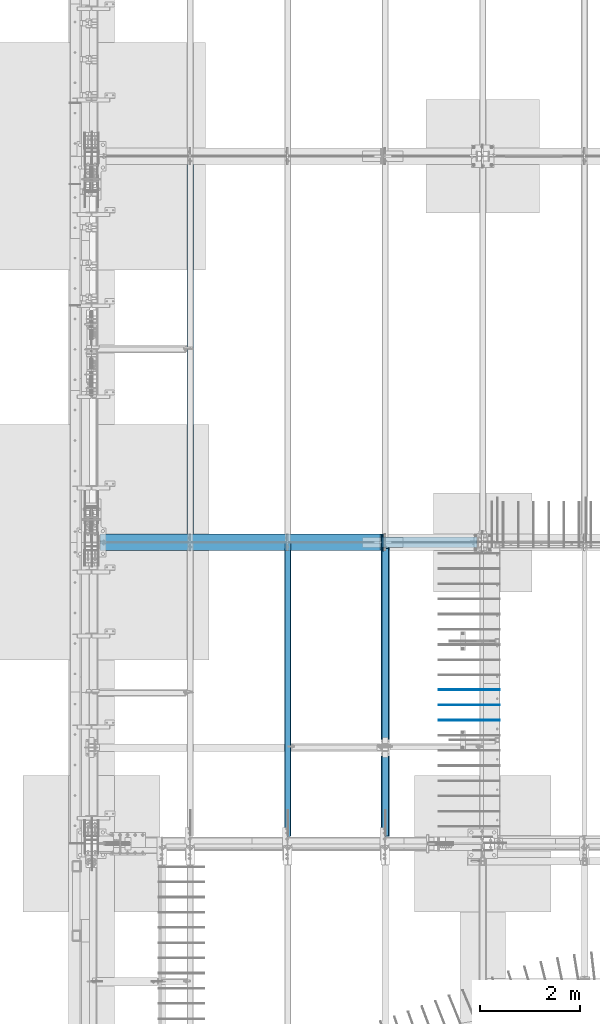
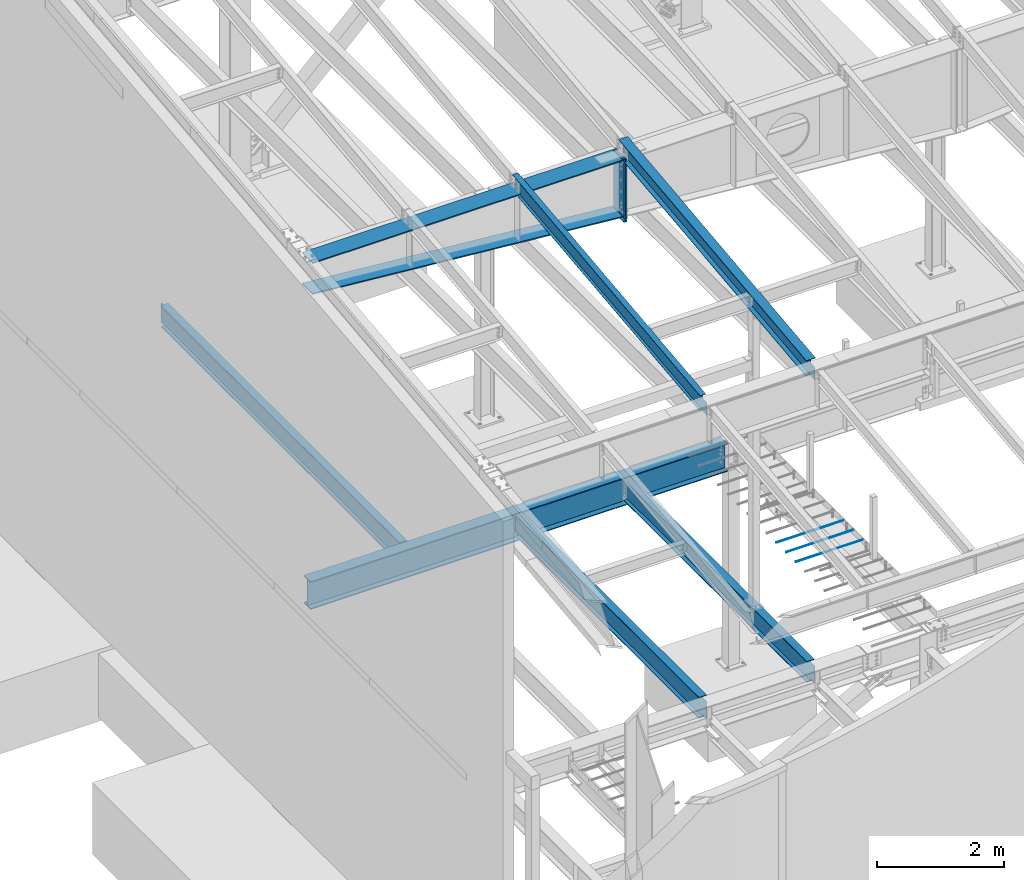
# One storey, part 709 of 1179: 13 beams, 11 elements without a shape of their own.
"""IFC2X3 building model written with IfcOpenShell, lengths in millimetres."""

from ifc_helpers import new_model, si_unit, frame, origin_with_axes, place, context, subcontext, project, spatial, faceted_brep, material, type_object, element, aggregate, save


model = new_model("IFC2X3")

# Units and contexts
model_context = context("Model", 3, precision=1e-05, world=origin_with_axes())
body_context = subcontext(model_context, "Body", "Model", "MODEL_VIEW")
ifc_project = project(units=[si_unit("LENGTHUNIT", "METRE", prefix="MILLI"), si_unit("AREAUNIT", "SQUARE_METRE"), si_unit("VOLUMEUNIT", "CUBIC_METRE"), si_unit("MASSUNIT", "GRAM", prefix="KILO"), si_unit("TIMEUNIT", "SECOND"), si_unit("PLANEANGLEUNIT", "RADIAN"), si_unit("SOLIDANGLEUNIT", "STERADIAN"), si_unit("THERMODYNAMICTEMPERATUREUNIT", "DEGREE_CELSIUS"), si_unit("LUMINOUSINTENSITYUNIT", "LUMEN")], contexts=[model_context])

# Site, building, storey
site_placement = place(None, origin_with_axes())
site = spatial("IfcSite", under=ifc_project, at=site_placement, CompositionType="ELEMENT")
building_placement = place(site_placement, origin_with_axes())
building = spatial("IfcBuilding", under=site, at=building_placement, Name="Undefined", CompositionType="ELEMENT")
storey_placement = place(building_placement, origin_with_axes())
storey = spatial("IfcBuildingStorey", under=building, at=storey_placement, Name="Undefined", CompositionType="ELEMENT", Elevation=0.0)

# Assembly, beam
assembly_1_placement = place(storey_placement, origin_with_axes())
assembly_1 = element("IfcElementAssembly", 1, at=assembly_1_placement, inside=storey, Name="BEAM", AssemblyPlace="NOTDEFINED", PredefinedType="RIGID_FRAME")
ifc_material_1 = material(Name="STEEL/A992")
beam_type_1 = type_object("IfcBeamType", Name="W12X14", PredefinedType="NOTDEFINED")
beam_1_placement = place(assembly_1_placement, frame((4368.8, 5452.5431792468, 9711.23798851528), z_axis=(0.0, -0.112284087038017, 0.993676146336441), x_axis=(0.0, 0.993676146336441, 0.112284087038017)))
beam_1 = element("IfcBeam", 2, at=beam_1_placement, type_object=beam_type_1, material=ifc_material_1, Name="BEAM", ObjectType="W12X14", context=body_context, shape_type="Brep", body=[
    faceted_brep([(-14.1944481268274, -2.38125000000036, -144.462499999927), (-14.9119897074661, -2.38115214811296, -150.812499999925), (137.488001223044, -2.38117577009325, -150.8125), (137.488001223013, -2.38125000000036, -144.462500000003), (137.48799371822, -50.7999999999993, -144.462500000005), (137.487993718216, -50.7999999999993, -150.812500000002), (5871.37503272929, 50.7999999999993, -144.462500002917), (5870.65749114864, 50.7999999999993, -150.812500002912), (137.488009517103, 50.7999999999993, -150.812500000002), (137.488009517107, 50.7999999999993, -144.462500000003), (137.488002012233, 2.3811758245356, -144.462500001737), (137.488002012265, 2.38132415558357, -150.812500000002), (-14.9119897074661, 2.38134777762207, -150.812499999925), (-14.1944481268274, 2.38125000000036, -144.462499999927), (5871.37503272928, 2.38124783346939, -144.462500002968), (6076.55490468175, 2.38124999999854, 144.462499996846), (6076.55490468175, 50.7999999999993, 144.462499996846), (6077.27244626239, 50.7999999999993, 150.812499996842), (6077.27244626239, -50.7999999999993, 150.812499996842), (6076.55490468175, -50.7999999999993, 144.462499996846), (6076.55490468175, -2.38124999999854, 144.462499996846), (6045.98095926941, -2.38124999999854, -126.106563095373), (6045.98095929506, 2.38124999999854, -126.10656309827), (5888.24414721426, -2.38124999999854, -108.282512497075), (5888.24414721426, 2.38122772319184, -108.282512497075), (5883.30625374162, -2.38124999999854, -108.697419370077), (5883.30625374162, 2.38122766974266, -108.697419370077), (5878.90301301472, -2.38124999999854, -110.970393360541), (5878.90301301472, 2.38122737693629, -110.970393360541), (5875.70477851863, -2.38124999999854, -114.755394783042), (5875.70477851863, 2.38122688934163, -114.755394783042), (5874.19845246322, -2.38124999999854, -119.476191482236), (5874.19845246322, 2.38122628119891, -119.476191482236), (5871.37503272929, -2.38124999999854, -144.462500002917), (5871.37503272929, -50.7999999999993, -144.462500002917), (5870.65749114864, -50.7999999999993, -150.812500002912), (-13.929041623056, -2.38125000000036, -142.113742318956), (12.2064158412222, -2.38125000000036, 89.176205714708), (12.2064158412222, 2.38125000000036, 89.176205714708), (-13.9290290466961, 2.38125000000036, -142.113631022425), (125.78359955719, -2.38125000000036, 76.342134544826), (125.78359955719, 2.38125000000036, 76.342134544826), (130.721493030343, -2.38125000000036, 76.7570414172296), (130.721493030343, 2.38125000000036, 76.7570414172296), (135.124733757862, -2.38125000000036, 79.0300154074976), (135.124733757862, 2.38125000000036, 79.0300154074976), (138.322968254461, -2.38125000000036, 82.8150168301745), (138.322968254461, 2.38125000000036, 82.8150168301745), (139.829294310099, -2.38125000000036, 87.5358135297793), (139.829294310099, 2.38125000000036, 87.5358135297793), (146.26193440305, 2.38125000000036, 144.46249999986), (146.26193440305, 50.7999999999993, 144.46249999986), (146.979475983694, 50.7999999999993, 150.812499999854), (146.979475983694, -50.7999999999993, 150.812499999854), (146.26193440305, -50.7999999999993, 144.46249999986), (146.26193440305, -2.38125000000036, 144.46249999986)], [[[0, 1, 2, 3]], [[4, 3, 2, 5]], [[6, 7, 8, 9]], [[10, 11, 12, 13]], [[9, 8, 11, 10]], [[14, 6, 9, 10]], [[15, 16, 17, 18, 19, 20, 21, 22]], [[21, 23, 24, 22]], [[25, 26, 24, 23]], [[27, 28, 26, 25]], [[29, 30, 28, 27]], [[31, 32, 30, 29]], [[33, 34, 35, 7, 6, 14, 32, 31]], [[35, 34, 4, 5]], [[1, 12, 11, 8, 7, 35, 5, 2]], [[36, 37, 38, 39, 13, 12, 1, 0]], [[40, 41, 38, 37]], [[42, 43, 41, 40]], [[44, 45, 43, 42]], [[46, 47, 45, 44]], [[48, 49, 47, 46]], [[15, 22, 24, 26, 28, 30, 32, 14, 10, 13, 39, 38, 41, 43, 45, 47, 49, 50]], [[16, 15, 50, 51]], [[17, 16, 51, 52]], [[18, 17, 52, 53]], [[19, 18, 53, 54]], [[20, 19, 54, 55]], [[53, 52, 51, 50, 49, 48, 55, 54]], [[46, 44, 42, 40, 37, 36, 0, 3, 33, 31, 29, 27, 25, 23, 21, 20, 55, 48]], [[34, 33, 3, 4]]]),
])
aggregate(assembly_1, [beam_1])

assembly_2_placement = place(storey_placement, origin_with_axes())
assembly_2 = element("IfcElementAssembly", 3, at=assembly_2_placement, inside=storey, Name="BEAM", AssemblyPlace="NOTDEFINED", PredefinedType="RIGID_FRAME")
beam_type_2 = type_object("IfcBeamType", Name="W16X31", PredefinedType="NOTDEFINED")
beam_2_placement = place(assembly_2_placement, frame((4368.80014508755, 5435.6, 3900.4875), z_axis=(0.0, 0.0, 1.0), x_axis=(0.0, 1.0, 0.0)))
beam_2 = element("IfcBeam", 4, at=beam_2_placement, type_object=beam_type_2, material=ifc_material_1, Name="BEAM", ObjectType="W16X31", context=body_context, shape_type="Brep", body=[
    faceted_brep([(19.0499999238054, -3.17500000000564, -147.6375), (19.0500000762049, 3.17499999999382, -147.6375), (141.287498514381, 3.17519843052196, -147.6375), (141.28749851438, -3.17500000003656, -147.6375), (146.147578032426, 3.17519914073091, -148.604229922588), (146.147578032425, -3.17500000003838, -148.604229922588), (150.26775450058, 3.175201160494, -151.357243823066), (150.267754500579, -3.17500000003838, -151.357243823066), (153.020768401058, 3.17520418232016, -155.47742029122), (153.020768401057, -3.1750000000402, -155.47742029122), (153.987498323645, -3.1750000000402, -160.337499809265), (153.987498323647, 3.17520774616514, -160.337499809265), (153.988000076218, 3.17556876199342, -190.5), (153.988000076218, 3.17556876199342, -201.6125), (153.987498323628, -69.8500000000395, -201.6125), (153.987498323628, -69.8500000000395, -190.5), (153.987498323645, -3.1750000000402, -190.5), (5900.73750167641, 69.8499999985015, -190.5), (5900.73750167641, 69.8499999985015, -201.6125), (153.988001676405, 69.8499999999603, -201.6125), (153.988001676405, 69.8499999999603, -190.5), (5900.73750007622, 3.17499999850133, -190.5), (5900.73750007622, 3.17542779204359, -201.6125), (6027.73750007621, 3.17499999846859, -190.5), (6027.73750007622, 3.17542474404308, -201.6125), (5927.72500167648, 69.8499999984942, 190.5), (5927.72500167647, 3.17499999849406, 190.5), (153.987498323646, 3.17499999996016, 190.5), (153.987498323663, 69.8499999999603, 190.5), (141.28749851438, -3.17500000003656, 169.8625), (141.287498514381, 3.17496707379814, 169.8625), (19.0500000762049, 3.17499999999382, 169.8625), (19.0499999238054, -3.17500000000564, 169.8625), (146.147578032425, -3.17500000003838, 170.829229922588), (146.147578032426, 3.17496636684882, 170.829229922588), (150.267754500579, -3.17500000003838, 173.582243823066), (150.26775450058, 3.17496435362955, 173.582243823066), (153.020768401057, -3.1750000000402, 177.702420291219), (153.020768401058, 3.17496134063458, 177.702420291219), (153.987498323645, -3.1750000000402, 182.562499809265), (153.987498323646, 3.17495778656485, 182.562499809265), (5927.72500167645, -69.8500000015056, 201.6125), (5927.72500167648, 69.8499999984942, 201.6125), (153.987498323663, 69.8499999999603, 201.6125), (153.987498323628, -69.8500000000395, 201.6125), (5927.72500167645, -69.8500000015056, 190.5), (153.987498323628, -69.8500000000395, 190.5), (5927.72500167647, -3.1750000015054, 190.5), (153.987498323645, -3.1750000000402, 190.5), (5927.72500167647, -3.1750000015054, 182.562499809265), (5927.72500167647, 3.17499999849406, 182.562499809265), (5928.69173159905, -3.1750000015054, 177.702420291219), (5928.69173159905, 3.17499999849406, 177.702420291219), (5931.44474549953, -3.17500000150721, 173.582243823066), (5931.44474549953, 3.17499999849315, 173.582243823066), (5935.56492196769, -3.17500000150812, 170.829229922588), (5935.56492196769, 3.17499999849224, 170.829229922588), (5940.42500148573, -3.17500000150903, 169.8625), (5940.42500148573, 3.17499999849133, 169.8625), (6027.73749992381, -3.17500000153177, 169.8625), (6027.73750007621, 3.17499999846859, 169.8625), (6027.73749992381, -3.17500000153177, -190.5), (6027.73749832361, -69.850000001531, -190.5), (6027.73749832361, -69.850000001531, -201.6125)], [[[0, 1, 2, 3]], [[3, 2, 4, 5]], [[5, 4, 6, 7]], [[7, 6, 8, 9]], [[10, 11, 12, 13, 14, 15, 16]], [[9, 8, 11, 10]], [[17, 18, 19, 20]], [[21, 22, 18, 17]], [[23, 24, 22, 21]], [[25, 26, 27, 28]], [[29, 30, 31, 32]], [[33, 34, 30, 29]], [[35, 36, 34, 33]], [[37, 38, 36, 35]], [[39, 40, 38, 37]], [[41, 42, 43, 44]], [[45, 41, 44, 46]], [[47, 45, 46, 48]], [[44, 43, 28, 27, 40, 39, 48, 46]], [[42, 25, 28, 43]], [[41, 45, 47, 49, 50, 26, 25, 42]], [[51, 52, 50, 49]], [[53, 54, 52, 51]], [[55, 56, 54, 53]], [[57, 58, 56, 55]], [[59, 60, 58, 57]], [[61, 62, 63, 24, 23, 60, 59]], [[62, 61, 16, 15]], [[63, 62, 15, 14]], [[19, 18, 22, 24, 63, 14, 13]], [[20, 19, 13, 12]], [[21, 17, 20, 12]], [[6, 4, 2, 1, 31, 30, 34, 36, 38, 40, 27, 26, 50, 52, 54, 56, 58, 60, 23, 21, 12, 11, 8]], [[32, 31, 1, 0]], [[61, 59, 57, 55, 53, 51, 49, 47, 48, 39, 37, 35, 33, 29, 32, 0, 3, 5, 7, 9, 10, 16]]]),
])
aggregate(assembly_2, [beam_2])

assembly_3_placement = place(storey_placement, origin_with_axes())
assembly_3 = element("IfcElementAssembly", 5, at=assembly_3_placement, inside=storey, Name="BEAM", AssemblyPlace="NOTDEFINED", PredefinedType="RIGID_FRAME")
beam_3_placement = place(assembly_3_placement, frame((2412.99985351563, 11480.8, 3900.4875), z_axis=(0.0, 0.0, 1.0), x_axis=(0.0, 1.0, 0.0)))
beam_3 = element("IfcBeam", 6, at=beam_3_placement, type_object=beam_type_2, material=ifc_material_1, Name="BEAM", ObjectType="W16X31", context=body_context, shape_type="Brep", body=[
    faceted_brep([(104.775000190735, -3.17499999999927, 169.8625), (104.775000190735, 3.17497090526012, 169.8625), (17.4625000000015, 3.17499999999927, 169.8625), (17.4625000000015, -3.17499999999927, 169.8625), (109.635079708782, -3.17499999999927, 170.829229922588), (109.635079708782, 3.17497028100843, 170.829229922588), (113.755256176935, -3.17499999999927, 173.582243823066), (113.755256176935, 3.17496850329189, 173.582243823066), (116.508270077413, -3.17499999999927, 177.702420291219), (116.508270077413, 3.17496584275432, 177.702420291219), (117.475, -3.17499999999927, 182.562499809265), (117.475, 3.17496270443371, 182.562499809265), (117.474999999999, -69.8499999999985, 201.6125), (117.474999999999, 69.8499999999985, 201.6125), (117.474999999999, 69.8499999999985, 190.5), (117.474999999999, 3.17499999999927, 190.5), (117.474999999999, -3.17499999999927, 190.5), (117.474999999999, -69.8499999999985, 190.5), (7601.74375, 3.17499999999927, -190.5), (7601.74375, 69.8499999999985, -190.5), (144.462499999994, 69.8499999999985, -190.5), (144.462499999994, 3.17549991607666, -190.5), (17.4624999999942, -3.17499999999927, -190.5), (17.4624999999942, -69.8499999999985, -190.5), (7728.74375, -69.8499999999985, -190.5), (7728.74375, -3.17499999999927, -190.5), (17.4624999999942, -69.8499999999985, -201.6125), (7728.74375, -69.8499999999985, -201.6125), (7601.74375, 69.8499999999985, -201.6125), (7601.74375, 3.17561705897606, -201.6125), (7728.74375, 3.17561705897606, -201.6125), (17.4624999999942, 3.17549991607666, -201.6125), (144.462499999994, 3.17549991607666, -201.6125), (144.462499999994, 69.8499999999985, -201.6125), (17.4624999999942, 3.17499999999927, -190.5), (7728.74375, 3.17499999999927, -190.5), (7728.74375, 3.17499999999927, 169.8625), (7728.74375, -3.17499999999927, 169.8625), (7633.49374980927, 3.17499999999927, 169.8625), (7633.49374980927, -3.17499999999927, 169.8625), (7628.63367029122, 3.17499999999927, 170.829229922588), (7628.63367029122, -3.17499999999927, 170.829229922588), (7624.51349382307, 3.17499999999927, 173.582243823066), (7624.51349382307, -3.17499999999927, 173.582243823066), (7621.76047992259, 3.17499999999927, 177.70242029122), (7621.76047992259, -3.17499999999927, 177.70242029122), (7620.79375, 3.17499999999927, 182.562499809265), (7620.79375, -3.17499999999927, 182.562499809265), (7620.79375, -69.8499999999985, 201.6125), (7620.79375, -69.8499999999985, 190.5), (7620.79375, -3.17499999999927, 190.5), (7620.79375, 3.17499999999927, 190.5), (7620.79375, 69.8499999999985, 190.5), (7620.79375, 69.8499999999985, 201.6125)], [[[0, 1, 2, 3]], [[4, 5, 1, 0]], [[6, 7, 5, 4]], [[8, 9, 7, 6]], [[10, 11, 9, 8]], [[12, 13, 14, 15, 11, 10, 16, 17]], [[18, 19, 20, 21]], [[22, 23, 24, 25]], [[23, 26, 27, 24]], [[28, 29, 30, 27, 26, 31, 32, 33]], [[21, 32, 31, 34]], [[20, 33, 32, 21]], [[19, 28, 33, 20]], [[18, 29, 28, 19]], [[35, 30, 29, 18]], [[25, 24, 27, 30, 35, 36, 37]], [[37, 36, 38, 39]], [[39, 38, 40, 41]], [[41, 40, 42, 43]], [[43, 42, 44, 45]], [[45, 44, 46, 47]], [[48, 49, 50, 47, 46, 51, 52, 53]], [[49, 48, 12, 17]], [[50, 49, 17, 16]], [[8, 6, 4, 0, 3, 22, 25, 37, 39, 41, 43, 45, 47, 50, 16, 10]], [[34, 31, 26, 23, 22, 3, 2]], [[51, 46, 44, 42, 40, 38, 36, 35, 18, 21, 34, 2, 1, 5, 7, 9, 11, 15]], [[52, 51, 15, 14]], [[53, 52, 14, 13]], [[48, 53, 13, 12]]]),
])
aggregate(assembly_3, [beam_3])

assembly_4_placement = place(storey_placement, origin_with_axes())
assembly_4 = element("IfcElementAssembly", 7, at=assembly_4_placement, inside=storey, Name="BEAM", AssemblyPlace="NOTDEFINED", PredefinedType="RIGID_FRAME")
beam_4_placement = place(assembly_4_placement, frame((6324.59996446262, 5435.6, 3900.4875), z_axis=(0.0, 0.0, 1.0), x_axis=(0.0, 1.0, 0.0)))
beam_4 = element("IfcBeam", 8, at=beam_4_placement, type_object=beam_type_2, material=ifc_material_1, Name="BEAM", ObjectType="W16X31", context=body_context, shape_type="Brep", body=[
    faceted_brep([(19.0499999238054, -3.17500000000564, -147.6375), (19.0500000762049, 3.17499999999382, -147.6375), (141.287498514381, 3.17519843052196, -147.6375), (141.28749851438, -3.17500000003656, -147.6375), (146.147578032426, 3.17519914073091, -148.604229922588), (146.147578032425, -3.17500000003838, -148.604229922588), (150.26775450058, 3.175201160494, -151.357243823066), (150.267754500579, -3.17500000003838, -151.357243823066), (153.020768401058, 3.17520418232016, -155.47742029122), (153.020768401057, -3.1750000000402, -155.47742029122), (153.987498323645, -3.1750000000402, -160.337499809265), (153.987498323647, 3.17520774616514, -160.337499809265), (153.987000000001, 3.17549991607757, -190.5), (153.987000000001, 3.17549991607757, -201.6125), (153.987498323628, -69.8500000000395, -201.6125), (153.987498323628, -69.8500000000395, -190.5), (153.987498323645, -3.1750000000402, -190.5), (5900.73750167641, 69.8499999985015, -190.5), (5900.73750167641, 69.8499999985015, -201.6125), (153.987000000001, 69.8500000000004, -201.6125), (153.987000000001, 69.8500000000004, -190.5), (5900.73750007622, 3.17499999850133, -190.5), (5900.73749999986, 3.17549991607666, -201.6125), (6027.73750007621, 3.17499999846859, -190.5), (6027.7375, 3.17549991607666, -201.6125), (5927.72500167648, 69.8499999984942, 190.5), (5927.72500167647, 3.17499999849406, 190.5), (153.987498323646, 3.17499999996016, 190.5), (153.987498323663, 69.8499999999603, 190.5), (141.28749851438, -3.17500000003656, 169.8625), (141.287498514381, 3.17496707379814, 169.8625), (19.0500000762049, 3.17499999999382, 169.8625), (19.0499999238054, -3.17500000000564, 169.8625), (146.147578032425, -3.17500000003838, 170.829229922588), (146.147578032426, 3.17496636684882, 170.829229922588), (150.267754500579, -3.17500000003838, 173.582243823066), (150.26775450058, 3.17496435362955, 173.582243823066), (153.020768401057, -3.1750000000402, 177.702420291219), (153.020768401058, 3.17496134063458, 177.702420291219), (153.987498323645, -3.1750000000402, 182.562499809265), (153.987498323646, 3.17495778656485, 182.562499809265), (5927.72500167645, -69.8500000015056, 201.6125), (5927.72500167648, 69.8499999984942, 201.6125), (153.987498323663, 69.8499999999603, 201.6125), (153.987498323628, -69.8500000000395, 201.6125), (5927.72500167645, -69.8500000015056, 190.5), (153.987498323628, -69.8500000000395, 190.5), (5927.72500167647, -3.1750000015054, 190.5), (153.987498323645, -3.1750000000402, 190.5), (5927.72500167647, -3.1750000015054, 182.562499809265), (5927.72500167647, 3.17499999849406, 182.562499809265), (5928.69173159905, -3.1750000015054, 177.702420291219), (5928.69173159905, 3.17499999849406, 177.702420291219), (5931.44474549953, -3.17500000150721, 173.582243823066), (5931.44474549953, 3.17499999849315, 173.582243823066), (5935.56492196769, -3.17500000150812, 170.829229922588), (5935.56492196769, 3.17499999849224, 170.829229922588), (5940.42500148573, -3.17500000150903, 169.8625), (5940.42500148573, 3.17499999849133, 169.8625), (6027.73749992381, -3.17500000153177, 169.8625), (6027.73750007621, 3.17499999846859, 169.8625), (6027.73749992381, -3.17500000153177, -190.5), (6027.73749832361, -69.850000001531, -190.5), (6027.73749832361, -69.850000001531, -201.6125)], [[[0, 1, 2, 3]], [[3, 2, 4, 5]], [[5, 4, 6, 7]], [[7, 6, 8, 9]], [[10, 11, 12, 13, 14, 15, 16]], [[9, 8, 11, 10]], [[17, 18, 19, 20]], [[21, 22, 18, 17]], [[23, 24, 22, 21]], [[25, 26, 27, 28]], [[29, 30, 31, 32]], [[33, 34, 30, 29]], [[35, 36, 34, 33]], [[37, 38, 36, 35]], [[39, 40, 38, 37]], [[41, 42, 43, 44]], [[45, 41, 44, 46]], [[47, 45, 46, 48]], [[44, 43, 28, 27, 40, 39, 48, 46]], [[42, 25, 28, 43]], [[41, 45, 47, 49, 50, 26, 25, 42]], [[51, 52, 50, 49]], [[53, 54, 52, 51]], [[55, 56, 54, 53]], [[57, 58, 56, 55]], [[59, 60, 58, 57]], [[61, 62, 63, 24, 23, 60, 59]], [[62, 61, 16, 15]], [[63, 62, 15, 14]], [[19, 18, 22, 24, 63, 14, 13]], [[20, 19, 13, 12]], [[21, 17, 20, 12]], [[6, 4, 2, 1, 31, 30, 34, 36, 38, 40, 27, 26, 50, 52, 54, 56, 58, 60, 23, 21, 12, 11, 8]], [[32, 31, 1, 0]], [[61, 59, 57, 55, 53, 51, 49, 47, 48, 39, 37, 35, 33, 29, 32, 0, 3, 5, 7, 9, 10, 16]]]),
])
aggregate(assembly_4, [beam_4])

assembly_5_placement = place(storey_placement, origin_with_axes())
assembly_5 = element("IfcElementAssembly", 9, at=assembly_5_placement, inside=storey, Name="RAFTER BEAM", AssemblyPlace="NOTDEFINED", PredefinedType="RIGID_FRAME")
ifc_material_2 = material(Name="STEEL/A36")
beam_type_3 = type_object("IfcBeamType", PredefinedType="NOTDEFINED")
beam_5_placement = place(assembly_5_placement, frame((6261.1, 11645.9093353614, 9647.25885710149), z_axis=(0.0, 0.0, 1.0), x_axis=(0.0, -1.0, 0.0)))
beam_5 = element("IfcBeam", 10, at=beam_5_placement, type_object=beam_type_3, material=ifc_material_2, Name="PLATE", context=body_context, shape_type="Brep", body=[
    faceted_brep([(0.0, 12.7000000000007, -604.8375), (0.0, 12.7000000000007, 604.8375), (330.199999998662, 12.7000000000007, 604.8375), (330.199999998662, 12.7000000000007, -604.8375), (0.0, -12.7000000000007, 604.8375), (330.199999998662, -12.7000000000007, 604.8375), (0.0, -12.7000000000007, -604.8375), (330.199999998662, -12.7000000000007, -604.8375)], [[[0, 1, 2, 3]], [[1, 4, 5, 2]], [[4, 6, 7, 5]], [[6, 0, 3, 7]], [[5, 7, 3, 2]], [[6, 4, 1, 0]]]),
])

assembly_6_placement = place(storey_placement, origin_with_axes())
assembly_6 = element("IfcElementAssembly", 11, at=assembly_6_placement, inside=storey, Name="RAFTER BEAM", AssemblyPlace="NOTDEFINED", PredefinedType="RIGID_FRAME")
beam_6_placement = place(assembly_6_placement, frame((6286.5, 11645.9093353614, 9647.25885710149), z_axis=(0.0, 0.0, 1.0), x_axis=(0.0, -1.0, 0.0)))
beam_6 = element("IfcBeam", 12, at=beam_6_placement, type_object=beam_type_3, material=ifc_material_2, Name="PLATE", context=body_context, shape_type="Brep", body=[
    faceted_brep([(0.0, 12.7000000000007, -604.8375), (0.0, 12.7000000000007, 604.8375), (330.199999998662, 12.7000000000007, 604.8375), (330.199999998662, 12.7000000000007, -604.8375), (0.0, -12.7000000000007, 604.8375), (330.199999998662, -12.7000000000007, 604.8375), (0.0, -12.7000000000007, -604.8375), (330.199999998662, -12.7000000000007, -604.8375)], [[[0, 1, 2, 3]], [[1, 4, 5, 2]], [[4, 6, 7, 5]], [[6, 0, 3, 7]], [[5, 7, 3, 2]], [[6, 4, 1, 0]]]),
])
aggregate(assembly_6, [beam_6])

# Beam
beam_type_4 = type_object("IfcBeamType", PredefinedType="NOTDEFINED")
beam_7_placement = place(assembly_5_placement, frame((600.692587263406, 11480.8093353628, 9653.73151088012), z_axis=(0.0, 1.0, 0.0), x_axis=(0.996183710890709, 0.0, -0.0872812359904244)))
beam_7 = element("IfcBeam", 13, at=beam_7_placement, type_object=beam_type_4, material=ifc_material_2, Name="PLATE", context=body_context, shape_type="Brep", body=[
    faceted_brep([(5670.3221448979, 11.172430163635, 165.1), (5643.908580592, -11.1125000006832, 165.1), (5643.908580592, -11.1125000006832, -165.1), (5670.31689408045, 11.1124999993244, -165.1), (1.66062363859965e-09, -11.1125000000084, -165.1), (1.66062363859965e-09, -11.1125000000084, 165.1), (1.94725676632936, 11.1125000000065, 165.1), (1.94725676632936, 11.1125000000065, -165.1)], [[[0, 1, 2, 3]], [[4, 5, 6, 7]], [[7, 6, 0, 3]], [[4, 7, 3, 2]], [[5, 4, 2, 1]], [[6, 5, 1, 0]]]),
])

beam_8_placement = place(assembly_5_placement, frame((601.662500000002, 11480.8093353614, 10240.98385672), z_axis=(0.0, -1.0, 0.0), x_axis=(1.0, 0.0, 0.0)))
beam_8 = element("IfcBeam", 14, at=beam_8_placement, type_object=beam_type_4, material=ifc_material_2, Name="PLATE", context=body_context, shape_type="Brep", body=[
    faceted_brep([(5646.7375, -11.1124999999993, 165.1), (5646.7375, -11.1124999999993, -165.1), (5624.51249961853, 11.1124999999993, -165.1), (5624.51249961853, 11.1124999999993, 165.1), (1.66062363859965e-09, -11.1125000000084, -165.1), (1.66062363859965e-09, -11.1125000000084, 165.1), (0.0, 11.1124999999993, 165.1), (0.0, 11.1124999999993, -165.1)], [[[0, 1, 2, 3]], [[4, 5, 6, 7]], [[6, 5, 0, 3]], [[7, 6, 3, 2]], [[4, 7, 2, 1]], [[5, 4, 1, 0]]]),
])

aggregate(assembly_5, [beam_5, beam_7, beam_8])

# Assembly, beam
assembly_7_placement = place(storey_placement, origin_with_axes())
assembly_7 = element("IfcElementAssembly", 15, at=assembly_7_placement, inside=storey, Name="#4 DOWEL", AssemblyPlace="NOTDEFINED", PredefinedType="NOTDEFINED")
ifc_material_3 = material(Name="REBAR/A615-40")
beam_type_5 = type_object("IfcBeamType", Name="#4 DOWEL", PredefinedType="NOTDEFINED")
beam_9_placement = place(assembly_7_placement, frame((7400.925, 8524.875, 4203.70000610352), z_axis=(0.0, 0.0, 1.0), x_axis=(1.0, 0.0, 0.0)))
beam_9 = element("IfcBeam", 16, at=beam_9_placement, type_object=beam_type_5, material=ifc_material_3, Name="#4 DOWEL", ObjectType="#4 DOWEL", context=body_context, shape_type="Brep", body=[
    faceted_brep([(0.0, -6.34999999999854, 0.0), (0.0, -4.49012806053361, -4.49012806053452), (1219.2, -4.49012806053543, -4.49012806053452), (1219.2, -6.35000000000036, 0.0), (0.0, 0.0, -6.34999999999991), (1219.2, 0.0, -6.35000000000036), (0.0, 4.49012806053361, -4.49012806053452), (1219.2, 4.49012806053543, -4.49012806053452), (0.0, 6.34999999999854, 0.0), (1219.2, 6.35000000000036, 0.0), (0.0, 4.49012806053361, 4.49012806053452), (1219.2, 4.49012806053543, 4.49012806053452), (0.0, 0.0, 6.34999999999991), (1219.2, 0.0, 6.35000000000036), (0.0, -4.49012806053361, 4.49012806053452), (1219.2, -4.49012806053543, 4.49012806053452)], [[[0, 1, 2, 3]], [[1, 4, 5, 2]], [[4, 6, 7, 5]], [[6, 8, 9, 7]], [[8, 10, 11, 9]], [[10, 12, 13, 11]], [[12, 14, 15, 13]], [[14, 0, 3, 15]], [[5, 7, 9, 11, 13, 15, 3, 2]], [[14, 12, 10, 8, 6, 4, 1, 0]]]),
])
aggregate(assembly_7, [beam_9])

assembly_8_placement = place(storey_placement, origin_with_axes())
assembly_8 = element("IfcElementAssembly", 17, at=assembly_8_placement, inside=storey, Name="#4 DOWEL", AssemblyPlace="NOTDEFINED", PredefinedType="NOTDEFINED")
beam_10_placement = place(assembly_8_placement, frame((7400.925, 8220.075, 4203.70000610352), z_axis=(0.0, 0.0, 1.0), x_axis=(1.0, 0.0, 0.0)))
beam_10 = element("IfcBeam", 18, at=beam_10_placement, type_object=beam_type_5, material=ifc_material_3, Name="#4 DOWEL", ObjectType="#4 DOWEL", context=body_context, shape_type="Brep", body=[
    faceted_brep([(0.0, -6.34999999999854, 0.0), (0.0, -4.49012806053361, -4.49012806053452), (1219.2, -4.49012806053543, -4.49012806053452), (1219.2, -6.35000000000036, 0.0), (0.0, 0.0, -6.34999999999991), (1219.2, 0.0, -6.35000000000036), (0.0, 4.49012806053361, -4.49012806053452), (1219.2, 4.49012806053543, -4.49012806053452), (0.0, 6.34999999999854, 0.0), (1219.2, 6.35000000000036, 0.0), (0.0, 4.49012806053361, 4.49012806053452), (1219.2, 4.49012806053543, 4.49012806053452), (0.0, 0.0, 6.34999999999991), (1219.2, 0.0, 6.35000000000036), (0.0, -4.49012806053361, 4.49012806053452), (1219.2, -4.49012806053543, 4.49012806053452)], [[[0, 1, 2, 3]], [[1, 4, 5, 2]], [[4, 6, 7, 5]], [[6, 8, 9, 7]], [[8, 10, 11, 9]], [[10, 12, 13, 11]], [[12, 14, 15, 13]], [[14, 0, 3, 15]], [[5, 7, 9, 11, 13, 15, 3, 2]], [[14, 12, 10, 8, 6, 4, 1, 0]]]),
])
aggregate(assembly_8, [beam_10])

assembly_9_placement = place(storey_placement, origin_with_axes())
assembly_9 = element("IfcElementAssembly", 19, at=assembly_9_placement, inside=storey, Name="#4 DOWEL", AssemblyPlace="NOTDEFINED", PredefinedType="NOTDEFINED")
beam_11_placement = place(assembly_9_placement, frame((7400.925, 7915.275, 4203.70000610352), z_axis=(0.0, 0.0, 1.0), x_axis=(1.0, 0.0, 0.0)))
beam_11 = element("IfcBeam", 20, at=beam_11_placement, type_object=beam_type_5, material=ifc_material_3, Name="#4 DOWEL", ObjectType="#4 DOWEL", context=body_context, shape_type="Brep", body=[
    faceted_brep([(0.0, -6.34999999999854, 0.0), (0.0, -4.49012806053361, -4.49012806053452), (1219.2, -4.49012806053543, -4.49012806053452), (1219.2, -6.35000000000036, 0.0), (0.0, 0.0, -6.34999999999991), (1219.2, 0.0, -6.35000000000036), (0.0, 4.49012806053361, -4.49012806053452), (1219.2, 4.49012806053543, -4.49012806053452), (0.0, 6.34999999999854, 0.0), (1219.2, 6.35000000000036, 0.0), (0.0, 4.49012806053361, 4.49012806053452), (1219.2, 4.49012806053543, 4.49012806053452), (0.0, 0.0, 6.34999999999991), (1219.2, 0.0, 6.35000000000036), (0.0, -4.49012806053361, 4.49012806053452), (1219.2, -4.49012806053543, 4.49012806053452)], [[[0, 1, 2, 3]], [[1, 4, 5, 2]], [[4, 6, 7, 5]], [[6, 8, 9, 7]], [[8, 10, 11, 9]], [[10, 12, 13, 11]], [[12, 14, 15, 13]], [[14, 0, 3, 15]], [[5, 7, 9, 11, 13, 15, 3, 2]], [[14, 12, 10, 8, 6, 4, 1, 0]]]),
])
aggregate(assembly_9, [beam_11])

assembly_10_placement = place(storey_placement, origin_with_axes())
assembly_10 = element("IfcElementAssembly", 21, at=assembly_10_placement, inside=storey, Name="BEAM", AssemblyPlace="NOTDEFINED", PredefinedType="RIGID_FRAME")
beam_type_6 = type_object("IfcBeamType", Name="W12X26", PredefinedType="NOTDEFINED")
beam_12_placement = place(assembly_10_placement, frame((6324.6, 5453.07793221234, 9706.50560586846), z_axis=(0.0, -0.112284087038017, 0.993676146336441), x_axis=(0.0, 0.993676146336441, 0.112284087038017)))
beam_12 = element("IfcBeam", 22, at=beam_12_placement, type_object=beam_type_6, material=ifc_material_1, Name="BEAM", ObjectType="W12X26", context=body_context, shape_type="Brep", body=[
    faceted_brep([(-14.9119897085029, -3.17500000000018, -146.049999999925), (-15.9883020794632, -3.1748646146134, -155.574999999921), (136.411682825233, -3.17489006541837, -155.574999999997), (136.411682825183, -3.17500000000018, -146.050000000001), (136.411669569569, -82.5500000000002, -146.050000000001), (136.411669569566, -82.5500000000002, -155.574999999997), (5864.80523527559, 82.5500000000002, -146.050000002911), (5863.72892290462, 82.5500000000002, -155.575000002906), (136.411697085463, 82.5500000000002, -155.574999999997), (136.411697085467, 82.5500000000002, -146.050000000001), (136.411683829707, 3.17488997619876, -146.050000002542), (136.411683829755, 3.17510998808302, -155.574999999997), (-15.9883020794632, 3.17513543897621, -155.574999999921), (-14.9119897085029, 3.17500000000018, -146.049999999925), (5864.80523527559, 3.17500000000018, -146.050000002911), (6076.73429007995, 3.17500000000018, 146.049999996847), (6076.73429007995, 82.5500000000002, 146.049999996847), (6077.81060245091, 82.5500000000002, 155.574999996843), (6077.81060245091, -82.5500000000002, 155.574999996843), (6076.73429007995, -82.5500000000002, 146.049999996847), (6076.73429007995, -3.17500000000018, 146.049999996847), (6047.93833838559, -3.17500000000018, -108.784420517371), (6047.93833844188, 3.17500000000018, -108.784420523731), (5883.89168280126, -3.17500000000018, -90.2473659664483), (5883.89168280126, 3.17500000000018, -90.2473659664483), (5878.9537893286, -3.17500000000018, -90.6622728394304), (5878.9537893286, 3.17500000000018, -90.6622728394304), (5874.55054860168, -3.17500000000018, -92.9352468298857), (5874.55054860168, 3.17500000000018, -92.9352468298857), (5871.35231410557, -3.17500000000018, -96.7202482523935), (5871.35231410557, 3.17500000000018, -96.7202482523935), (5869.84598805015, -3.17500000000018, -101.441044951604), (5869.84598805015, 3.17500000000018, -101.441044951604), (5864.80523527559, -3.17500000000018, -146.050000002911), (5864.80523527559, -82.5500000000002, -146.050000002911), (5863.72892290462, -82.5500000000002, -155.575000002906), (-14.2878957904959, -3.17500000000018, -140.526980169054), (12.2064158401845, -3.17500000000018, 93.9387057147069), (12.2064158401845, 3.17500000000018, 93.9387057147069), (-14.2878792095371, 3.17500000000018, -140.526833433187), (125.783599556145, -3.17500000000018, 81.1046345448249), (125.783599556145, 3.17500000000018, 81.1046345448249), (130.721493029298, -3.17500000000018, 81.5195414172267), (130.721493029298, 3.17500000000018, 81.5195414172267), (135.124733756817, -3.17500000000018, 83.7925154074965), (135.124733756817, 3.17500000000018, 83.7925154074965), (138.322968253416, -3.17500000000018, 87.5775168301716), (138.322968253416, 3.17500000000018, 87.5775168301716), (139.829294309053, -3.17500000000018, 92.2983135297764), (139.829294309053, 3.17500000000018, 92.2983135297764), (145.903163611682, 3.17500000000018, 146.049999999861), (145.903163611682, 82.5500000000002, 146.049999999861), (146.97947598265, 82.5500000000002, 155.574999999855), (146.97947598265, -82.5500000000002, 155.574999999855), (145.903163611682, -82.5500000000002, 146.049999999861), (145.903163611682, -3.17500000000018, 146.049999999861)], [[[0, 1, 2, 3]], [[4, 3, 2, 5]], [[6, 7, 8, 9]], [[10, 11, 12, 13]], [[9, 8, 11, 10]], [[14, 6, 9, 10]], [[15, 16, 17, 18, 19, 20, 21, 22]], [[21, 23, 24, 22]], [[25, 26, 24, 23]], [[27, 28, 26, 25]], [[29, 30, 28, 27]], [[31, 32, 30, 29]], [[33, 34, 35, 7, 6, 14, 32, 31]], [[35, 34, 4, 5]], [[1, 12, 11, 8, 7, 35, 5, 2]], [[36, 37, 38, 39, 13, 12, 1, 0]], [[40, 41, 38, 37]], [[42, 43, 41, 40]], [[44, 45, 43, 42]], [[46, 47, 45, 44]], [[48, 49, 47, 46]], [[15, 22, 24, 26, 28, 30, 32, 14, 10, 13, 39, 38, 41, 43, 45, 47, 49, 50]], [[16, 15, 50, 51]], [[17, 16, 51, 52]], [[18, 17, 52, 53]], [[19, 18, 53, 54]], [[20, 19, 54, 55]], [[53, 52, 51, 50, 49, 48, 55, 54]], [[46, 44, 42, 40, 37, 36, 0, 3, 33, 31, 29, 27, 25, 23, 21, 20, 55, 48]], [[34, 33, 3, 4]]]),
])
aggregate(assembly_10, [beam_12])

assembly_11_placement = place(storey_placement, origin_with_axes())
assembly_11 = element("IfcElementAssembly", 23, at=assembly_11_placement, inside=storey, Name="BEAM", AssemblyPlace="NOTDEFINED", PredefinedType="RIGID_FRAME")
beam_type_7 = type_object("IfcBeamType", Name="W21X62", PredefinedType="NOTDEFINED")
beam_13_placement = place(assembly_11_placement, frame((431.800000000002, 11480.8, 3835.4), z_axis=(0.0, 0.0, 1.0), x_axis=(1.0, 0.0, 0.0)))
beam_13 = element("IfcBeam", 24, at=beam_13_placement, type_object=beam_type_7, material=ifc_material_1, Name="BEAM", ObjectType="W21X62", context=body_context, shape_type="Brep", body=[
    faceted_brep([(169.862500816437, -104.775000000001, -250.825), (169.862500816437, -104.775000000001, -266.7), (7734.3, -104.775, -266.7), (7734.3, -104.775, -250.825), (169.8625, -4.76250000000073, -250.825), (7734.3, -4.76250000000073, -250.825), (169.8625, -4.76250000000073, 250.825), (7734.3, -4.76250000000073, 250.825), (169.862500816437, -104.775000000001, 250.825), (7734.3, -104.775, 250.825), (169.862500816437, -104.775000000001, 266.7), (7734.3, -104.775, 266.7), (169.862500816437, 104.775000000001, 266.7), (7734.3, 104.775, 266.7), (169.862500816437, 104.775000000001, 250.825), (7734.3, 104.775, 250.825), (169.8625, 4.76250000000073, 250.825), (7734.3, 4.76250000000073, 250.825), (169.8625, 4.76250000000073, -250.825), (7734.3, 4.76250000000073, -250.825), (169.862500816437, 104.775000000001, -250.825), (7734.3, 104.775, -250.825), (169.862500816437, 104.775000000001, -266.7), (7734.3, 104.775, -266.7)], [[[0, 1, 2, 3]], [[4, 0, 3, 5]], [[6, 4, 5, 7]], [[8, 6, 7, 9]], [[10, 8, 9, 11]], [[12, 10, 11, 13]], [[14, 12, 13, 15]], [[16, 14, 15, 17]], [[18, 16, 17, 19]], [[20, 18, 19, 21]], [[1, 0, 4, 6, 8, 10, 12, 14, 16, 18, 20, 22]], [[1, 22, 23, 2]], [[19, 17, 15, 13, 11, 9, 7, 5, 3, 2, 23, 21]], [[22, 20, 21, 23]]]),
])
aggregate(assembly_11, [beam_13])

save(model, "model.ifc")
